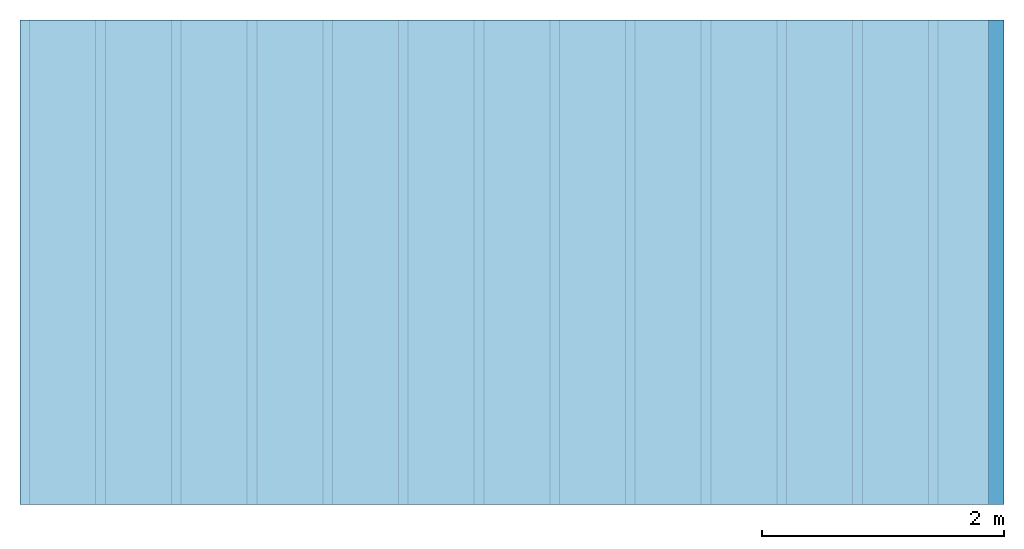
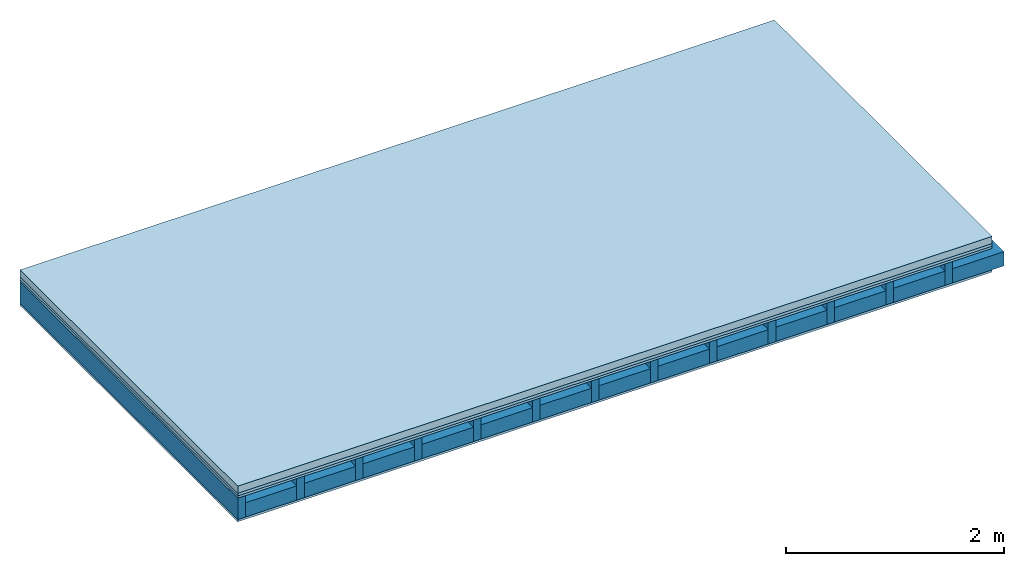
# One storey: 4 plates, 2 members, 1 element without a shape of its own.
"""IFC4 building model written with IfcOpenShell, lengths in metres."""

from ifc_helpers import new_model, si_unit, derived_unit, direction, frame, frame_2d, origin, origin_with_axes, place, context, project, spatial, rectangle, extrude, material, layer, layer_set, type_object, element, aggregate, save


model = new_model("IFC4")

# Units and contexts
plan_context = context("Plan", 3, precision=1e-05, world=origin(), true_north=direction((0.0, 1.0)))
model_context = context("Model", 3, precision=1e-05, world=origin(), true_north=direction((0.0, 1.0)))
ifc_project = project(units=[si_unit("LENGTHUNIT", "METRE"), derived_unit("SOUNDPRESSUREUNIT", [(si_unit("PRESSUREUNIT", "PASCAL", prefix="MICRO"), 0)]), si_unit("ENERGYUNIT", "JOULE", prefix="MEGA"), si_unit("MASSUNIT", "GRAM", prefix="KILO"), derived_unit("THERMALTRANSMITTANCEUNIT", [(si_unit("POWERUNIT", "WATT"), 1), (si_unit("AREAUNIT", "SQUARE_METRE"), -1), (si_unit("THERMODYNAMICTEMPERATUREUNIT", "KELVIN"), -1)]), derived_unit("AREADENSITYUNIT", [(si_unit("MASSUNIT", "GRAM", prefix="KILO"), 1), (si_unit("AREAUNIT", "SQUARE_METRE"), -1)]), derived_unit("USERDEFINED", [(si_unit("ENERGYUNIT", "JOULE", prefix="MEGA"), 1), (si_unit("AREAUNIT", "SQUARE_METRE"), -1)])], contexts=[plan_context, model_context])

# Site, building, storey
site = spatial("IfcSite", under=ifc_project)
building_placement = place(None, origin())
building = spatial("IfcBuilding", under=site, at=building_placement)
storey_placement = place(building_placement, origin())
storey = spatial("IfcBuildingStorey", under=building, at=storey_placement)

# Slab, members, plates
ifc_material_1 = material(Name="Cement screed", Category="04.006")
ifc_layer_1 = layer(ifc_material_1, 0.08, Name="On-material")
ifc_material_2 = material()
ifc_layer_2 = layer(ifc_material_2, 0.03, Name="Impact sound insulation")
ifc_material_3 = material(Category="07.001")
ifc_layer_3 = layer(ifc_material_3, 0.025, Name="Sub-floor")
ifc_material_4 = material(Name="Rigid, of the art")
ifc_layer_4 = layer(ifc_material_4, 0.0, Name="Bond")
ifc_layer_5 = layer(None, 0.24, Name="Supporting structure")
ifc_layer_6 = layer(ifc_material_4, 0.0, Name="Bond")
ifc_layer_7 = layer(ifc_material_3, 0.025, Name="Lower layer 1")
ifc_layer_set = layer_set([ifc_layer_1, ifc_layer_2, ifc_layer_3, ifc_layer_4, ifc_layer_5, ifc_layer_6, ifc_layer_7])
slab_type = type_object("IfcSlabType", Name="A0293", PredefinedType="NOTDEFINED", material=ifc_layer_set)
slab_placement = place(None, frame((0.0, 0.0, 0.0), z_axis=(0.0, 0.0, -1.0), x_axis=(1.0, 0.0, 0.0)))
slab = element("IfcSlab", 1, at=slab_placement, inside=storey, type_object=slab_type, material=ifc_layer_set, Name="Slab #1")
ifc_material_5 = material()
member_1_placement = place(slab_placement, origin())
member_1 = element("IfcMember", 2, at=member_1_placement, material=ifc_material_5, Name="Supporting structure", context=plan_context, shape_type="SweptSolid", body=[
    extrude(rectangle(XDim=0.08, YDim=0.24, at=frame_2d((0.04, 0.12), x_axis=(1.0, 0.0))), frame((0.0, 4.0, 0.135), z_axis=(0.0, -1.0, 0.0), x_axis=(1.0, 0.0, 0.0)), (0.0, 0.0, 1.0), 4.0),
    extrude(rectangle(XDim=0.08, YDim=0.24, at=frame_2d((0.04, 0.12), x_axis=(1.0, 0.0))), frame((0.625, 4.0, 0.135), z_axis=(0.0, -1.0, 0.0), x_axis=(1.0, 0.0, 0.0)), (0.0, 0.0, 1.0), 4.0),
    extrude(rectangle(XDim=0.08, YDim=0.24, at=frame_2d((0.04, 0.12), x_axis=(1.0, 0.0))), frame((1.25, 4.0, 0.135), z_axis=(0.0, -1.0, 0.0), x_axis=(1.0, 0.0, 0.0)), (0.0, 0.0, 1.0), 4.0),
    extrude(rectangle(XDim=0.08, YDim=0.24, at=frame_2d((0.04, 0.12), x_axis=(1.0, 0.0))), frame((1.875, 4.0, 0.135), z_axis=(0.0, -1.0, 0.0), x_axis=(1.0, 0.0, 0.0)), (0.0, 0.0, 1.0), 4.0),
    extrude(rectangle(XDim=0.08, YDim=0.24, at=frame_2d((0.04, 0.12), x_axis=(1.0, 0.0))), frame((2.5, 4.0, 0.135), z_axis=(0.0, -1.0, 0.0), x_axis=(1.0, 0.0, 0.0)), (0.0, 0.0, 1.0), 4.0),
    extrude(rectangle(XDim=0.08, YDim=0.24, at=frame_2d((0.04, 0.12), x_axis=(1.0, 0.0))), frame((3.125, 4.0, 0.135), z_axis=(0.0, -1.0, 0.0), x_axis=(1.0, 0.0, 0.0)), (0.0, 0.0, 1.0), 4.0),
    extrude(rectangle(XDim=0.08, YDim=0.24, at=frame_2d((0.04, 0.12), x_axis=(1.0, 0.0))), frame((3.75, 4.0, 0.135), z_axis=(0.0, -1.0, 0.0), x_axis=(1.0, 0.0, 0.0)), (0.0, 0.0, 1.0), 4.0),
    extrude(rectangle(XDim=0.08, YDim=0.24, at=frame_2d((0.04, 0.12), x_axis=(1.0, 0.0))), frame((4.375, 4.0, 0.135), z_axis=(0.0, -1.0, 0.0), x_axis=(1.0, 0.0, 0.0)), (0.0, 0.0, 1.0), 4.0),
    extrude(rectangle(XDim=0.08, YDim=0.24, at=frame_2d((0.04, 0.12), x_axis=(1.0, 0.0))), frame((5.0, 4.0, 0.135), z_axis=(0.0, -1.0, 0.0), x_axis=(1.0, 0.0, 0.0)), (0.0, 0.0, 1.0), 4.0),
    extrude(rectangle(XDim=0.08, YDim=0.24, at=frame_2d((0.04, 0.12), x_axis=(1.0, 0.0))), frame((5.625, 4.0, 0.135), z_axis=(0.0, -1.0, 0.0), x_axis=(1.0, 0.0, 0.0)), (0.0, 0.0, 1.0), 4.0),
    extrude(rectangle(XDim=0.08, YDim=0.24, at=frame_2d((0.04, 0.12), x_axis=(1.0, 0.0))), frame((6.25, 4.0, 0.135), z_axis=(0.0, -1.0, 0.0), x_axis=(1.0, 0.0, 0.0)), (0.0, 0.0, 1.0), 4.0),
    extrude(rectangle(XDim=0.08, YDim=0.24, at=frame_2d((0.04, 0.12), x_axis=(1.0, 0.0))), frame((6.875, 4.0, 0.135), z_axis=(0.0, -1.0, 0.0), x_axis=(1.0, 0.0, 0.0)), (0.0, 0.0, 1.0), 4.0),
    extrude(rectangle(XDim=0.08, YDim=0.24, at=frame_2d((0.04, 0.12), x_axis=(1.0, 0.0))), frame((7.5, 4.0, 0.135), z_axis=(0.0, -1.0, 0.0), x_axis=(1.0, 0.0, 0.0)), (0.0, 0.0, 1.0), 4.0),
])
ifc_material_6 = material()
member_2_placement = place(slab_placement, origin())
member_2 = element("IfcMember", 3, at=member_2_placement, material=ifc_material_6, Name="Cavity", context=plan_context, shape_type="SweptSolid", body=[
    extrude(rectangle(XDim=0.545, YDim=0.16, at=frame_2d((0.2725, 0.08), x_axis=(1.0, 0.0))), frame((0.08, 4.0, 0.215), z_axis=(0.0, -1.0, 0.0), x_axis=(1.0, 0.0, 0.0)), (0.0, 0.0, 1.0), 4.0),
    extrude(rectangle(XDim=0.545, YDim=0.16, at=frame_2d((0.2725, 0.08), x_axis=(1.0, 0.0))), frame((0.705, 4.0, 0.215), z_axis=(0.0, -1.0, 0.0), x_axis=(1.0, 0.0, 0.0)), (0.0, 0.0, 1.0), 4.0),
    extrude(rectangle(XDim=0.545, YDim=0.16, at=frame_2d((0.2725, 0.08), x_axis=(1.0, 0.0))), frame((1.33, 4.0, 0.215), z_axis=(0.0, -1.0, 0.0), x_axis=(1.0, 0.0, 0.0)), (0.0, 0.0, 1.0), 4.0),
    extrude(rectangle(XDim=0.545, YDim=0.16, at=frame_2d((0.2725, 0.08), x_axis=(1.0, 0.0))), frame((1.955, 4.0, 0.215), z_axis=(0.0, -1.0, 0.0), x_axis=(1.0, 0.0, 0.0)), (0.0, 0.0, 1.0), 4.0),
    extrude(rectangle(XDim=0.545, YDim=0.16, at=frame_2d((0.2725, 0.08), x_axis=(1.0, 0.0))), frame((2.58, 4.0, 0.215), z_axis=(0.0, -1.0, 0.0), x_axis=(1.0, 0.0, 0.0)), (0.0, 0.0, 1.0), 4.0),
    extrude(rectangle(XDim=0.545, YDim=0.16, at=frame_2d((0.2725, 0.08), x_axis=(1.0, 0.0))), frame((3.205, 4.0, 0.215), z_axis=(0.0, -1.0, 0.0), x_axis=(1.0, 0.0, 0.0)), (0.0, 0.0, 1.0), 4.0),
    extrude(rectangle(XDim=0.545, YDim=0.16, at=frame_2d((0.2725, 0.08), x_axis=(1.0, 0.0))), frame((3.83, 4.0, 0.215), z_axis=(0.0, -1.0, 0.0), x_axis=(1.0, 0.0, 0.0)), (0.0, 0.0, 1.0), 4.0),
    extrude(rectangle(XDim=0.545, YDim=0.16, at=frame_2d((0.2725, 0.08), x_axis=(1.0, 0.0))), frame((4.455, 4.0, 0.215), z_axis=(0.0, -1.0, 0.0), x_axis=(1.0, 0.0, 0.0)), (0.0, 0.0, 1.0), 4.0),
    extrude(rectangle(XDim=0.545, YDim=0.16, at=frame_2d((0.2725, 0.08), x_axis=(1.0, 0.0))), frame((5.08, 4.0, 0.215), z_axis=(0.0, -1.0, 0.0), x_axis=(1.0, 0.0, 0.0)), (0.0, 0.0, 1.0), 4.0),
    extrude(rectangle(XDim=0.545, YDim=0.16, at=frame_2d((0.2725, 0.08), x_axis=(1.0, 0.0))), frame((5.705, 4.0, 0.215), z_axis=(0.0, -1.0, 0.0), x_axis=(1.0, 0.0, 0.0)), (0.0, 0.0, 1.0), 4.0),
    extrude(rectangle(XDim=0.545, YDim=0.16, at=frame_2d((0.2725, 0.08), x_axis=(1.0, 0.0))), frame((6.33, 4.0, 0.215), z_axis=(0.0, -1.0, 0.0), x_axis=(1.0, 0.0, 0.0)), (0.0, 0.0, 1.0), 4.0),
    extrude(rectangle(XDim=0.545, YDim=0.16, at=frame_2d((0.2725, 0.08), x_axis=(1.0, 0.0))), frame((6.955, 4.0, 0.215), z_axis=(0.0, -1.0, 0.0), x_axis=(1.0, 0.0, 0.0)), (0.0, 0.0, 1.0), 4.0),
    extrude(rectangle(XDim=0.545, YDim=0.16, at=frame_2d((0.2725, 0.08), x_axis=(1.0, 0.0))), frame((7.58, 4.0, 0.215), z_axis=(0.0, -1.0, 0.0), x_axis=(1.0, 0.0, 0.0)), (0.0, 0.0, 1.0), 4.0),
])
plate_1_placement = place(slab_placement, origin())
plate_1 = element("IfcPlate", 4, at=plate_1_placement, material=ifc_material_1, Name="On-material", context=plan_context, shape_type="SweptSolid", body=[
    extrude(rectangle(XDim=8.0, YDim=4.0, at=frame_2d((4.0, 2.0), x_axis=(1.0, 0.0))), origin_with_axes(), (0.0, 0.0, 1.0), 0.08),
])
plate_2_placement = place(slab_placement, origin())
plate_2 = element("IfcPlate", 5, at=plate_2_placement, material=ifc_material_2, Name="Impact sound insulation", context=plan_context, shape_type="SweptSolid", body=[
    extrude(rectangle(XDim=8.0, YDim=4.0, at=frame_2d((4.0, 2.0), x_axis=(1.0, 0.0))), frame((0.0, 0.0, 0.08), z_axis=(0.0, 0.0, 1.0), x_axis=(1.0, 0.0, 0.0)), (0.0, 0.0, 1.0), 0.03),
])
plate_3_placement = place(slab_placement, origin())
plate_3 = element("IfcPlate", 6, at=plate_3_placement, material=ifc_material_3, Name="Sub-floor", context=plan_context, shape_type="SweptSolid", body=[
    extrude(rectangle(XDim=8.0, YDim=4.0, at=frame_2d((4.0, 2.0), x_axis=(1.0, 0.0))), frame((0.0, 0.0, 0.11), z_axis=(0.0, 0.0, 1.0), x_axis=(1.0, 0.0, 0.0)), (0.0, 0.0, 1.0), 0.025),
])
plate_4_placement = place(slab_placement, origin())
plate_4 = element("IfcPlate", 7, at=plate_4_placement, material=ifc_material_3, Name="Lower layer 1", context=plan_context, shape_type="SweptSolid", body=[
    extrude(rectangle(XDim=8.0, YDim=4.0, at=frame_2d((4.0, 2.0), x_axis=(1.0, 0.0))), frame((0.0, 0.0, 0.375), z_axis=(0.0, 0.0, 1.0), x_axis=(1.0, 0.0, 0.0)), (0.0, 0.0, 1.0), 0.025),
])
aggregate(slab, [plate_1, plate_2, plate_3, member_1, member_2, plate_4])

save(model, "model.ifc")
